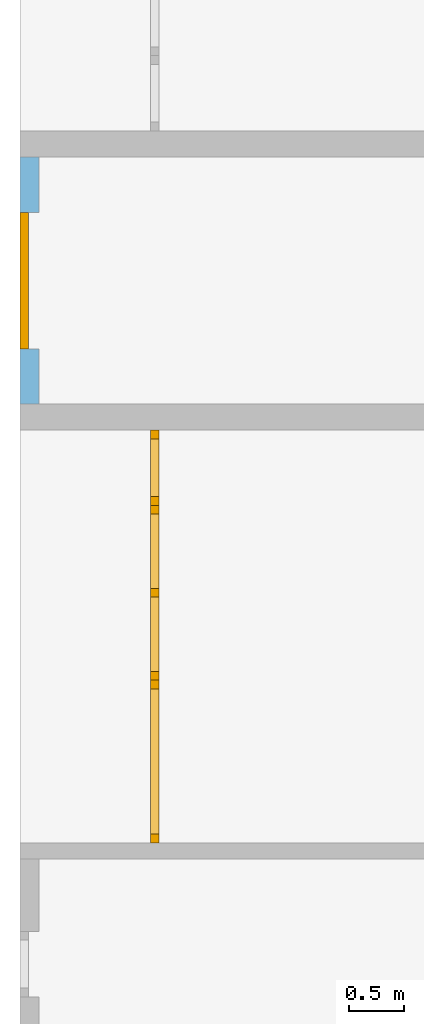
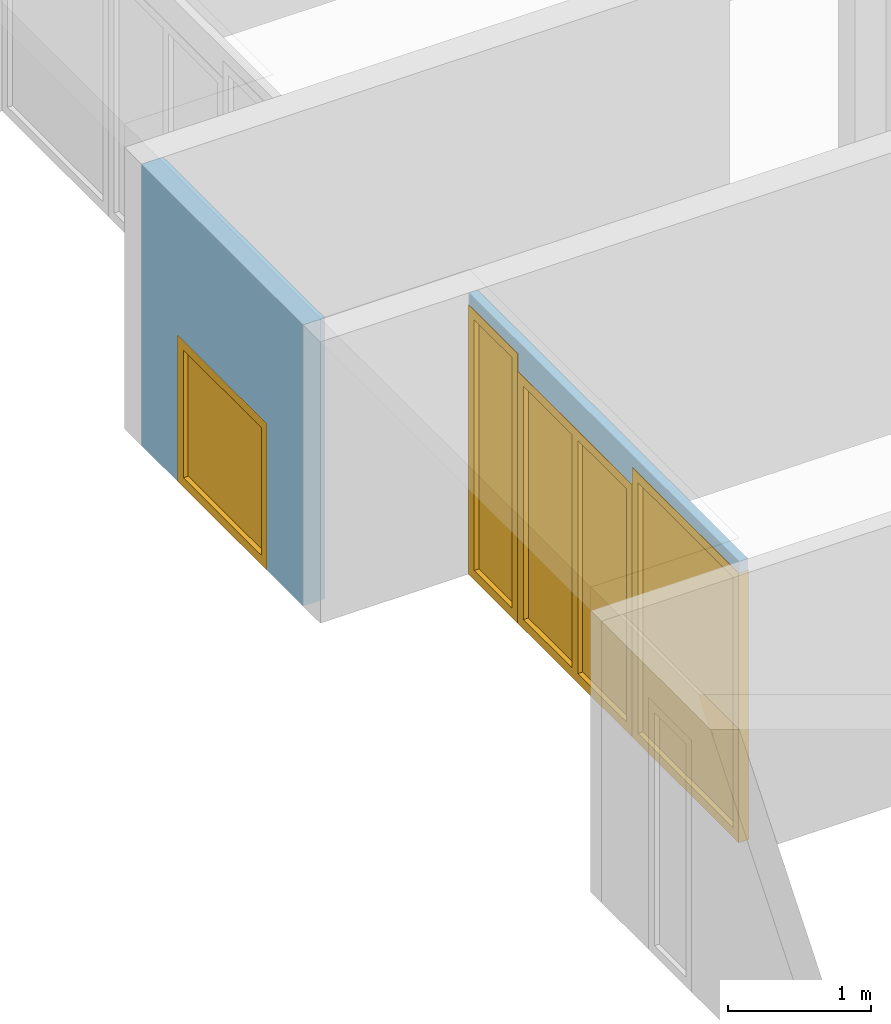
# One storey, part 4 of 8: 2 doors, 2 windows, 4 openings, plus 2 elements that do not belong to this part.
"""IFC2X3 building model written with IfcOpenShell, lengths in millimetres."""

from ifc_helpers import new_model, entity, si_unit, converted_unit, frame, frame_2d, origin, origin_with_axes, place, context, project, spatial, rectangle, extrude, faceted_brep, material, layer, layer_set, layer_usage, type_object, element, fill, save


model = new_model("IFC2X3")

# Units and contexts
model_context = context("Model", 3, precision=1e-05, world=origin())
plan_context = context("Plan", 3, precision=1e-05, world=origin())
ifc_project = project(units=[si_unit("LENGTHUNIT", "METRE", prefix="MILLI"), converted_unit("PLANEANGLEUNIT", "DEGREE", entity("IfcPlaneAngleMeasure", 0.0174532925199433), si_unit("PLANEANGLEUNIT", "RADIAN"), dimensions=[0, 0, 0, 0, 0, 0, 0]), si_unit("AREAUNIT", "SQUARE_METRE"), si_unit("VOLUMEUNIT", "CUBIC_METRE")], contexts=[model_context, plan_context])

# Building, storey
building_placement = place(None, origin())
building = spatial("IfcBuilding", under=ifc_project, at=building_placement, CompositionType="ELEMENT")
storey_placement = place(building_placement, frame((0.0, 0.0, 2900.0), z_axis=(0.0, 0.0, 1.0), x_axis=(1.0, 0.0, 0.0)))
storey = spatial("IfcBuildingStorey", under=building, at=storey_placement, Name="OG", CompositionType="ELEMENT", Elevation=2900.0)

# Wall, opening, window
ifc_material_1 = material(Name="B25")
ifc_layer_1 = layer(ifc_material_1, 175.0)
ifc_layer_set_1 = layer_set([ifc_layer_1])
ifc_layer_usage_1 = layer_usage(ifc_layer_set_1, "AXIS2", "POSITIVE", 0.0)
wall_1_placement = place(storey_placement, frame((21188.3517822139, 1688.4375, 0.0), z_axis=(0.0, 0.0, 1.0), x_axis=(-1.64835853914244e-12, -1.0, 0.0)))
wall_1 = element("IfcWallStandardCase", 1, at=wall_1_placement, inside=storey, material=ifc_layer_usage_1, context=model_context, shape_type="SweptSolid", body=[
    extrude(rectangle(XDim=2260.0, YDim=175.0, at=frame_2d((1130.0, 87.5), x_axis=(1.0, 0.0))), origin_with_axes(), (0.0, 0.0, 1.0), 2400.0),
])
opening_1_placement = place(wall_1_placement, frame((505.000000000001, -8.54925019665361e-13, 0.0), z_axis=(0.0, 1.0, 0.0), x_axis=(0.0, 0.0, 1.0)))
opening_1 = element("IfcOpeningElement", 2, at=opening_1_placement, cuts=wall_1, ObjectType="Opening", context=model_context, shape_type="SweptSolid", body=[
    extrude(rectangle(XDim=1250.0, YDim=1250.0, at=frame_2d((625.0, 625.0), x_axis=(1.0, 0.0))), origin_with_axes(), (0.0, 0.0, 1.0), 175.0),
])
ifc_material_2 = material()
window_1_placement = place(opening_1_placement, frame((0.0, 0.0, 0.0), z_axis=(1.0, 0.0, 0.0), x_axis=(0.0, 1.0, 0.0)))
window_1 = element("IfcWindow", 3, at=window_1_placement, inside=storey, material=ifc_material_2, Name="m", OverallHeight=1250.0, OverallWidth=1250.0, context=model_context, shape_type="Brep", body=[
    faceted_brep([(79.9999999997119, -8.9765050947932e-10, 0.0), (-2.88082446786575e-10, -1.02951436264931e-09, 0.0), (-2.88082446786575e-10, -1.02951436264931e-09, 1250.0), (79.9999999997119, -8.9765050947932e-10, 1250.0), (-4.1995917854365e-10, 79.9999999989705, 0.0), (79.99999999958, 79.9999999991024, 0.0), (79.99999999958, 79.9999999991024, 1250.0), (-4.1995917854365e-10, 79.9999999989705, 1250.0), (-2.88082446786575e-10, -1.02951436264931e-09, 0.0), (79.9999999997119, -8.9765050947932e-10, 0.0), (79.99999999958, 79.9999999991024, 0.0), (-4.1995917854365e-10, 79.9999999989705, 0.0), (-2.88082446786575e-10, -1.02951436264931e-09, 1250.0), (-2.88082446786575e-10, -1.02951436264931e-09, 0.0), (-4.1995917854365e-10, 79.9999999989705, 0.0), (-4.1995917854365e-10, 79.9999999989705, 1250.0), (79.9999999997119, -8.9765050947932e-10, 1250.0), (-2.88082446786575e-10, -1.02951436264931e-09, 1250.0), (-4.1995917854365e-10, 79.9999999989705, 1250.0), (79.99999999958, 79.9999999991024, 1250.0), (79.9999999997119, -8.9765050947932e-10, 0.0), (79.9999999997119, -8.9765050947932e-10, 1250.0), (79.99999999958, 79.9999999991024, 1250.0), (79.99999999958, 79.9999999991024, 0.0)], [[[0, 1, 2, 3]], [[4, 5, 6, 7]], [[8, 9, 10, 11]], [[12, 13, 14, 15]], [[16, 17, 18, 19]], [[20, 21, 22, 23]]], orient=[[False], [False], [False], [False], [False], [False]]),
    faceted_brep([(1170.00000000013, 8.98979335417494e-10, 1250.0), (1250.00000000013, 1.03084307756518e-09, 1250.0), (1250.00000000013, 1.03084307756518e-09, 0.0), (1170.00000000013, 8.98979335417494e-10, 0.0), (1250.0, 80.0000000010309, 1250.0), (1170.0, 80.000000000899, 1250.0), (1170.0, 80.000000000899, 0.0), (1250.0, 80.0000000010309, 0.0), (1250.00000000013, 1.03084307756518e-09, 1250.0), (1170.00000000013, 8.98979335417494e-10, 1250.0), (1170.0, 80.000000000899, 1250.0), (1250.0, 80.0000000010309, 1250.0), (1250.00000000013, 1.03084307756518e-09, 0.0), (1250.00000000013, 1.03084307756518e-09, 1250.0), (1250.0, 80.0000000010309, 1250.0), (1250.0, 80.0000000010309, 0.0), (1170.00000000013, 8.98979335417494e-10, 0.0), (1250.00000000013, 1.03084307756518e-09, 0.0), (1250.0, 80.0000000010309, 0.0), (1170.0, 80.000000000899, 0.0), (1170.00000000013, 8.98979335417494e-10, 1250.0), (1170.00000000013, 8.98979335417494e-10, 0.0), (1170.0, 80.000000000899, 0.0), (1170.0, 80.000000000899, 1250.0)], [[[0, 1, 2, 3]], [[4, 5, 6, 7]], [[8, 9, 10, 11]], [[12, 13, 14, 15]], [[16, 17, 18, 19]], [[20, 21, 22, 23]]], orient=[[False], [False], [False], [False], [False], [False]]),
    faceted_brep([(1170.00000000013, 8.98965124562778e-10, 80.0), (1170.00000000013, 8.98965124562778e-10, 0.0), (79.9999999997137, -8.9767893118875e-10, 0.0), (79.9999999997137, -8.9767893118875e-10, 80.0), (1170.0, 80.000000000899, 0.0), (1170.0, 80.000000000899, 80.0), (79.9999999995819, 79.9999999991023, 80.0), (79.9999999995819, 79.9999999991023, 0.0), (1170.00000000013, 8.98965124562778e-10, 0.0), (1170.00000000013, 8.98965124562778e-10, 80.0), (1170.0, 80.000000000899, 80.0), (1170.0, 80.000000000899, 0.0), (79.9999999997137, -8.9767893118875e-10, 0.0), (1170.00000000013, 8.98965124562778e-10, 0.0), (1170.0, 80.000000000899, 0.0), (79.9999999995819, 79.9999999991023, 0.0), (79.9999999997137, -8.9767893118875e-10, 80.0), (79.9999999997137, -8.9767893118875e-10, 0.0), (79.9999999995819, 79.9999999991023, 0.0), (79.9999999995819, 79.9999999991023, 80.0), (1170.00000000013, 8.98965124562778e-10, 80.0), (79.9999999997137, -8.9767893118875e-10, 80.0), (79.9999999995819, 79.9999999991023, 80.0), (1170.0, 80.000000000899, 80.0)], [[[0, 1, 2, 3]], [[4, 5, 6, 7]], [[8, 9, 10, 11]], [[12, 13, 14, 15]], [[16, 17, 18, 19]], [[20, 21, 22, 23]]], orient=[[False], [False], [False], [False], [False], [False]]),
    faceted_brep([(79.9999999997137, -8.9767893118875e-10, 1170.0), (79.9999999997137, -8.9767893118875e-10, 1250.0), (1170.00000000013, 8.98965124562778e-10, 1250.0), (1170.00000000013, 8.98965124562778e-10, 1170.0), (79.9999999995819, 79.9999999991023, 1250.0), (79.9999999995819, 79.9999999991023, 1170.0), (1170.0, 80.000000000899, 1170.0), (1170.0, 80.000000000899, 1250.0), (79.9999999997137, -8.9767893118875e-10, 1250.0), (79.9999999997137, -8.9767893118875e-10, 1170.0), (79.9999999995819, 79.9999999991023, 1170.0), (79.9999999995819, 79.9999999991023, 1250.0), (1170.00000000013, 8.98965124562778e-10, 1250.0), (79.9999999997137, -8.9767893118875e-10, 1250.0), (79.9999999995819, 79.9999999991023, 1250.0), (1170.0, 80.000000000899, 1250.0), (1170.00000000013, 8.98965124562778e-10, 1170.0), (1170.00000000013, 8.98965124562778e-10, 1250.0), (1170.0, 80.000000000899, 1250.0), (1170.0, 80.000000000899, 1170.0), (79.9999999997137, -8.9767893118875e-10, 1170.0), (1170.00000000013, 8.98965124562778e-10, 1170.0), (1170.0, 80.000000000899, 1170.0), (79.9999999995819, 79.9999999991023, 1170.0)], [[[0, 1, 2, 3]], [[4, 5, 6, 7]], [[8, 9, 10, 11]], [[12, 13, 14, 15]], [[16, 17, 18, 19]], [[20, 21, 22, 23]]], orient=[[False], [False], [False], [False], [False], [False]]),
    faceted_brep([(1170.00000000007, 40.000000000899, 1170.0), (1170.00000000007, 40.000000000899, 80.0), (79.9999999996455, 39.9999999991023, 80.0), (79.9999999996455, 39.9999999991023, 1170.0), (1170.00000000006, 41.000000000899, 1170.0), (79.9999999996439, 40.9999999991023, 1170.0), (79.9999999996439, 40.9999999991023, 80.0), (1170.00000000006, 41.000000000899, 80.0), (1170.00000000007, 40.000000000899, 1170.0), (1170.00000000006, 41.000000000899, 1170.0), (1170.00000000006, 41.000000000899, 80.0), (1170.00000000007, 40.000000000899, 80.0), (1170.00000000007, 40.000000000899, 80.0), (1170.00000000006, 41.000000000899, 80.0), (79.9999999996439, 40.9999999991023, 80.0), (79.9999999996455, 39.9999999991023, 80.0), (79.9999999996455, 39.9999999991023, 80.0), (79.9999999996439, 40.9999999991023, 80.0), (79.9999999996439, 40.9999999991023, 1170.0), (79.9999999996455, 39.9999999991023, 1170.0), (79.9999999996455, 39.9999999991023, 1170.0), (79.9999999996439, 40.9999999991023, 1170.0), (1170.00000000006, 41.000000000899, 1170.0), (1170.00000000007, 40.000000000899, 1170.0)], [[[0, 1, 2, 3]], [[4, 5, 6, 7]], [[8, 9, 10, 11]], [[12, 13, 14, 15]], [[16, 17, 18, 19]], [[20, 21, 22, 23]]], orient=[[False], [False], [False], [False], [False], [False]]),
])
fill(opening_1, window_1)

# Wall, openings, doors, window
ifc_material_3 = material(Name="glas")
ifc_layer_2 = layer(ifc_material_3, 70.0)
ifc_layer_set_2 = layer_set([ifc_layer_2])
ifc_layer_usage_2 = layer_usage(ifc_layer_set_2, "AXIS2", "POSITIVE", 0.0)
wall_2_placement = place(storey_placement, frame((22458.3517822139, -4591.5625, 0.0), z_axis=(0.0, 0.0, 1.0), x_axis=(0.0, 1.0, 0.0)))
wall_2 = element("IfcWallStandardCase", 4, at=wall_2_placement, inside=storey, material=ifc_layer_usage_2, context=model_context, shape_type="SweptSolid", body=[
    extrude(rectangle(XDim=3780.0, YDim=70.0, at=frame_2d((1890.0, 35.0), x_axis=(1.0, 0.0))), origin_with_axes(), (0.0, 0.0, 1.0), 2400.0),
])
opening_2_placement = place(wall_2_placement, frame((1490.0, 0.0, 0.0), z_axis=(0.0, 1.0, 0.0), x_axis=(0.0, 0.0, 1.0)))
opening_2 = element("IfcOpeningElement", 5, at=opening_2_placement, cuts=wall_2, ObjectType="Opening", context=model_context, shape_type="SweptSolid", body=[
    extrude(rectangle(XDim=2150.0, YDim=1600.0, at=frame_2d((1075.0, 800.0), x_axis=(1.0, 0.0))), origin_with_axes(), (0.0, 0.0, 1.0), 70.0),
])
opening_3_placement = place(wall_2_placement, frame((3090.0, 0.0, 0.0), z_axis=(0.0, 1.0, 0.0), x_axis=(0.0, 0.0, 1.0)))
opening_3 = element("IfcOpeningElement", 6, at=opening_3_placement, cuts=wall_2, ObjectType="Opening", context=model_context, shape_type="SweptSolid", body=[
    extrude(rectangle(XDim=2300.0, YDim=689.999999999996, at=frame_2d((1150.0, 344.999999999998), x_axis=(1.0, 0.0))), origin_with_axes(), (0.0, 0.0, 1.0), 70.0),
])
opening_4_placement = place(wall_2_placement, frame((0.0, 0.0, 0.0), z_axis=(0.0, 1.0, 0.0), x_axis=(0.0, 0.0, 1.0)))
opening_4 = element("IfcOpeningElement", 7, at=opening_4_placement, cuts=wall_2, ObjectType="Opening", context=model_context, shape_type="SweptSolid", body=[
    extrude(rectangle(XDim=2300.0, YDim=1490.0, at=frame_2d((1150.0, 745.0), x_axis=(1.0, 0.0))), origin_with_axes(), (0.0, 0.0, 1.0), 70.0),
])
ifc_material_4 = material()
door_style_1 = type_object("IfcDoorStyle", Name="Verglasung 01", ConstructionType="NOTDEFINED", OperationType="USERDEFINED", ParameterTakesPrecedence=False, Sizeable=False)
door_1_placement = place(opening_3_placement, frame((0.0, 0.0, 0.0), z_axis=(1.0, 0.0, 0.0), x_axis=(0.0, 1.0, 0.0)))
door_1 = element("IfcDoor", 8, at=door_1_placement, inside=storey, type_object=door_style_1, material=ifc_material_4, Name="Verglasung 01", OverallHeight=2300.0, OverallWidth=690.0, context=model_context, shape_type="Brep", body=[
    faceted_brep([(609.999999999996, 75.0000000000014, 0.0), (689.999999999996, 75.0000000000014, 0.0), (689.999999999996, 75.0000000000014, 2300.0), (609.999999999996, 75.0000000000014, 2300.0), (689.999999999996, -4.99999999999859, 0.0), (609.999999999996, -4.99999999999859, 0.0), (609.999999999996, -4.99999999999859, 2300.0), (689.999999999996, -4.99999999999859, 2300.0), (689.999999999996, 75.0000000000014, 0.0), (609.999999999996, 75.0000000000014, 0.0), (609.999999999996, -4.99999999999859, 0.0), (689.999999999996, -4.99999999999859, 0.0), (689.999999999996, 75.0000000000014, 2300.0), (689.999999999996, 75.0000000000014, 0.0), (689.999999999996, -4.99999999999859, 0.0), (689.999999999996, -4.99999999999859, 2300.0), (609.999999999996, 75.0000000000014, 2300.0), (689.999999999996, 75.0000000000014, 2300.0), (689.999999999996, -4.99999999999859, 2300.0), (609.999999999996, -4.99999999999859, 2300.0), (609.999999999996, 75.0000000000014, 0.0), (609.999999999996, 75.0000000000014, 2300.0), (609.999999999996, -4.99999999999859, 2300.0), (609.999999999996, -4.99999999999859, 0.0)], [[[0, 1, 2, 3]], [[4, 5, 6, 7]], [[8, 9, 10, 11]], [[12, 13, 14, 15]], [[16, 17, 18, 19]], [[20, 21, 22, 23]]], orient=[[False], [False], [False], [False], [False], [False]]),
    faceted_brep([(80.0, 75.0000000000015, 2300.0), (3.34279265644953e-16, 75.0000000000015, 2300.0), (3.34279265644953e-16, 75.0000000000015, 0.0), (80.0, 75.0000000000015, 0.0), (-4.56414614964456e-15, -4.99999999999854, 2300.0), (80.0, -4.99999999999854, 2300.0), (80.0, -4.99999999999854, 0.0), (-4.56414614964456e-15, -4.99999999999854, 0.0), (3.34279265644953e-16, 75.0000000000015, 2300.0), (80.0, 75.0000000000015, 2300.0), (80.0, -4.99999999999854, 2300.0), (-4.56414614964456e-15, -4.99999999999854, 2300.0), (3.34279265644953e-16, 75.0000000000015, 0.0), (3.34279265644953e-16, 75.0000000000015, 2300.0), (-4.56414614964456e-15, -4.99999999999854, 2300.0), (-4.56414614964456e-15, -4.99999999999854, 0.0), (80.0, 75.0000000000015, 0.0), (3.34279265644953e-16, 75.0000000000015, 0.0), (-4.56414614964456e-15, -4.99999999999854, 0.0), (80.0, -4.99999999999854, 0.0), (80.0, 75.0000000000015, 2300.0), (80.0, 75.0000000000015, 0.0), (80.0, -4.99999999999854, 0.0), (80.0, -4.99999999999854, 2300.0)], [[[0, 1, 2, 3]], [[4, 5, 6, 7]], [[8, 9, 10, 11]], [[12, 13, 14, 15]], [[16, 17, 18, 19]], [[20, 21, 22, 23]]], orient=[[False], [False], [False], [False], [False], [False]]),
    faceted_brep([(609.999999999996, 75.0000000000014, 2220.0), (609.999999999996, 75.0000000000014, 2300.0), (80.0, 75.0000000000015, 2300.0), (80.0, 75.0000000000015, 2220.0), (609.999999999996, -4.99999999999858, 2300.0), (609.999999999996, -4.99999999999858, 2220.0), (80.0, -4.99999999999854, 2220.0), (80.0, -4.99999999999854, 2300.0), (609.999999999996, 75.0000000000014, 2300.0), (609.999999999996, 75.0000000000014, 2220.0), (609.999999999996, -4.99999999999858, 2220.0), (609.999999999996, -4.99999999999858, 2300.0), (80.0, 75.0000000000015, 2300.0), (609.999999999996, 75.0000000000014, 2300.0), (609.999999999996, -4.99999999999858, 2300.0), (80.0, -4.99999999999854, 2300.0), (80.0, 75.0000000000015, 2220.0), (80.0, 75.0000000000015, 2300.0), (80.0, -4.99999999999854, 2300.0), (80.0, -4.99999999999854, 2220.0), (609.999999999996, 75.0000000000014, 2220.0), (80.0, 75.0000000000015, 2220.0), (80.0, -4.99999999999854, 2220.0), (609.999999999996, -4.99999999999858, 2220.0)], [[[0, 1, 2, 3]], [[4, 5, 6, 7]], [[8, 9, 10, 11]], [[12, 13, 14, 15]], [[16, 17, 18, 19]], [[20, 21, 22, 23]]], orient=[[False], [False], [False], [False], [False], [False]]),
    faceted_brep([(80.0, 75.0000000000015, 80.0), (80.0, 75.0000000000015, 0.0), (609.999999999996, 75.0000000000014, 0.0), (609.999999999996, 75.0000000000014, 80.0), (80.0, -4.99999999999854, 0.0), (80.0, -4.99999999999854, 80.0), (609.999999999996, -4.99999999999858, 80.0), (609.999999999996, -4.99999999999858, 0.0), (80.0, 75.0000000000015, 0.0), (80.0, 75.0000000000015, 80.0), (80.0, -4.99999999999854, 80.0), (80.0, -4.99999999999854, 0.0), (609.999999999996, 75.0000000000014, 0.0), (80.0, 75.0000000000015, 0.0), (80.0, -4.99999999999854, 0.0), (609.999999999996, -4.99999999999858, 0.0), (609.999999999996, 75.0000000000014, 80.0), (609.999999999996, 75.0000000000014, 0.0), (609.999999999996, -4.99999999999858, 0.0), (609.999999999996, -4.99999999999858, 80.0), (80.0, 75.0000000000015, 80.0), (609.999999999996, 75.0000000000014, 80.0), (609.999999999996, -4.99999999999858, 80.0), (80.0, -4.99999999999854, 80.0)], [[[0, 1, 2, 3]], [[4, 5, 6, 7]], [[8, 9, 10, 11]], [[12, 13, 14, 15]], [[16, 17, 18, 19]], [[20, 21, 22, 23]]], orient=[[False], [False], [False], [False], [False], [False]]),
    faceted_brep([(609.999999999996, 35.0000000000014, 80.0), (609.999999999996, 35.0000000000014, 2220.0), (80.0, 35.0000000000015, 2220.0), (80.0, 35.0000000000015, 80.0), (609.999999999996, 34.0000000000014, 80.0), (80.0, 34.0000000000015, 80.0), (80.0, 34.0000000000015, 2220.0), (609.999999999996, 34.0000000000014, 2220.0), (609.999999999996, 35.0000000000014, 80.0), (609.999999999996, 34.0000000000014, 80.0), (609.999999999996, 34.0000000000014, 2220.0), (609.999999999996, 35.0000000000014, 2220.0), (609.999999999996, 35.0000000000014, 2220.0), (609.999999999996, 34.0000000000014, 2220.0), (80.0, 34.0000000000015, 2220.0), (80.0, 35.0000000000015, 2220.0), (80.0, 35.0000000000015, 2220.0), (80.0, 34.0000000000015, 2220.0), (80.0, 34.0000000000015, 80.0), (80.0, 35.0000000000015, 80.0), (80.0, 35.0000000000015, 80.0), (80.0, 34.0000000000015, 80.0), (609.999999999996, 34.0000000000014, 80.0), (609.999999999996, 35.0000000000014, 80.0)], [[[0, 1, 2, 3]], [[4, 5, 6, 7]], [[8, 9, 10, 11]], [[12, 13, 14, 15]], [[16, 17, 18, 19]], [[20, 21, 22, 23]]], orient=[[False], [False], [False], [False], [False], [False]]),
])
fill(opening_3, door_1)
ifc_material_5 = material()
door_style_2 = type_object("IfcDoorStyle", Name="m", ConstructionType="NOTDEFINED", OperationType="USERDEFINED", ParameterTakesPrecedence=False, Sizeable=False)
door_2_placement = place(opening_4_placement, frame((0.0, 0.0, 0.0), z_axis=(1.0, 0.0, 0.0), x_axis=(0.0, 1.0, 0.0)))
door_2 = element("IfcDoor", 9, at=door_2_placement, inside=storey, type_object=door_style_2, material=ifc_material_5, Name="m", OverallHeight=2300.0, OverallWidth=1490.0, context=model_context, shape_type="Brep", body=[
    faceted_brep([(1410.0, 75.0000000000014, 0.0), (1490.0, 75.0000000000014, 0.0), (1490.0, 75.0000000000014, 2300.0), (1410.0, 75.0000000000014, 2300.0), (1490.0, -4.99999999999864, 0.0), (1410.0, -4.99999999999864, 0.0), (1410.0, -4.99999999999864, 2300.0), (1490.0, -4.99999999999864, 2300.0), (1490.0, 75.0000000000014, 0.0), (1410.0, 75.0000000000014, 0.0), (1410.0, -4.99999999999864, 0.0), (1490.0, -4.99999999999864, 0.0), (1490.0, 75.0000000000014, 2300.0), (1490.0, 75.0000000000014, 0.0), (1490.0, -4.99999999999864, 0.0), (1490.0, -4.99999999999864, 2300.0), (1410.0, 75.0000000000014, 2300.0), (1490.0, 75.0000000000014, 2300.0), (1490.0, -4.99999999999864, 2300.0), (1410.0, -4.99999999999864, 2300.0), (1410.0, 75.0000000000014, 0.0), (1410.0, 75.0000000000014, 2300.0), (1410.0, -4.99999999999864, 2300.0), (1410.0, -4.99999999999864, 0.0)], [[[0, 1, 2, 3]], [[4, 5, 6, 7]], [[8, 9, 10, 11]], [[12, 13, 14, 15]], [[16, 17, 18, 19]], [[20, 21, 22, 23]]], orient=[[False], [False], [False], [False], [False], [False]]),
    faceted_brep([(80.0, 75.0000000000015, 2300.0), (3.34279265644953e-16, 75.0000000000015, 2300.0), (3.34279265644953e-16, 75.0000000000015, 0.0), (80.0, 75.0000000000015, 0.0), (-4.56414614964456e-15, -4.99999999999854, 2300.0), (80.0, -4.99999999999854, 2300.0), (80.0, -4.99999999999854, 0.0), (-4.56414614964456e-15, -4.99999999999854, 0.0), (3.34279265644953e-16, 75.0000000000015, 2300.0), (80.0, 75.0000000000015, 2300.0), (80.0, -4.99999999999854, 2300.0), (-4.56414614964456e-15, -4.99999999999854, 2300.0), (3.34279265644953e-16, 75.0000000000015, 0.0), (3.34279265644953e-16, 75.0000000000015, 2300.0), (-4.56414614964456e-15, -4.99999999999854, 2300.0), (-4.56414614964456e-15, -4.99999999999854, 0.0), (80.0, 75.0000000000015, 0.0), (3.34279265644953e-16, 75.0000000000015, 0.0), (-4.56414614964456e-15, -4.99999999999854, 0.0), (80.0, -4.99999999999854, 0.0), (80.0, 75.0000000000015, 2300.0), (80.0, 75.0000000000015, 0.0), (80.0, -4.99999999999854, 0.0), (80.0, -4.99999999999854, 2300.0)], [[[0, 1, 2, 3]], [[4, 5, 6, 7]], [[8, 9, 10, 11]], [[12, 13, 14, 15]], [[16, 17, 18, 19]], [[20, 21, 22, 23]]], orient=[[False], [False], [False], [False], [False], [False]]),
    faceted_brep([(1410.0, 75.0000000000014, 2220.0), (1410.0, 75.0000000000014, 2300.0), (80.0, 75.0000000000015, 2300.0), (80.0, 75.0000000000015, 2220.0), (1410.0, -4.99999999999862, 2300.0), (1410.0, -4.99999999999862, 2220.0), (80.0, -4.99999999999854, 2220.0), (80.0, -4.99999999999854, 2300.0), (1410.0, 75.0000000000014, 2300.0), (1410.0, 75.0000000000014, 2220.0), (1410.0, -4.99999999999862, 2220.0), (1410.0, -4.99999999999862, 2300.0), (80.0, 75.0000000000015, 2300.0), (1410.0, 75.0000000000014, 2300.0), (1410.0, -4.99999999999862, 2300.0), (80.0, -4.99999999999854, 2300.0), (80.0, 75.0000000000015, 2220.0), (80.0, 75.0000000000015, 2300.0), (80.0, -4.99999999999854, 2300.0), (80.0, -4.99999999999854, 2220.0), (1410.0, 75.0000000000014, 2220.0), (80.0, 75.0000000000015, 2220.0), (80.0, -4.99999999999854, 2220.0), (1410.0, -4.99999999999862, 2220.0)], [[[0, 1, 2, 3]], [[4, 5, 6, 7]], [[8, 9, 10, 11]], [[12, 13, 14, 15]], [[16, 17, 18, 19]], [[20, 21, 22, 23]]], orient=[[False], [False], [False], [False], [False], [False]]),
    faceted_brep([(80.0, 75.0000000000015, 80.0), (80.0, 75.0000000000015, 0.0), (1410.0, 75.0000000000014, 0.0), (1410.0, 75.0000000000014, 80.0), (80.0, -4.99999999999854, 0.0), (80.0, -4.99999999999854, 80.0), (1410.0, -4.99999999999862, 80.0), (1410.0, -4.99999999999862, 0.0), (80.0, 75.0000000000015, 0.0), (80.0, 75.0000000000015, 80.0), (80.0, -4.99999999999854, 80.0), (80.0, -4.99999999999854, 0.0), (1410.0, 75.0000000000014, 0.0), (80.0, 75.0000000000015, 0.0), (80.0, -4.99999999999854, 0.0), (1410.0, -4.99999999999862, 0.0), (1410.0, 75.0000000000014, 80.0), (1410.0, 75.0000000000014, 0.0), (1410.0, -4.99999999999862, 0.0), (1410.0, -4.99999999999862, 80.0), (80.0, 75.0000000000015, 80.0), (1410.0, 75.0000000000014, 80.0), (1410.0, -4.99999999999862, 80.0), (80.0, -4.99999999999854, 80.0)], [[[0, 1, 2, 3]], [[4, 5, 6, 7]], [[8, 9, 10, 11]], [[12, 13, 14, 15]], [[16, 17, 18, 19]], [[20, 21, 22, 23]]], orient=[[False], [False], [False], [False], [False], [False]]),
    faceted_brep([(1410.0, 35.0000000000014, 80.0), (1410.0, 35.0000000000014, 2220.0), (80.0, 35.0000000000015, 2220.0), (80.0, 35.0000000000015, 80.0), (1410.0, 34.0000000000014, 80.0), (80.0, 34.0000000000015, 80.0), (80.0, 34.0000000000015, 2220.0), (1410.0, 34.0000000000014, 2220.0), (1410.0, 35.0000000000014, 80.0), (1410.0, 34.0000000000014, 80.0), (1410.0, 34.0000000000014, 2220.0), (1410.0, 35.0000000000014, 2220.0), (1410.0, 35.0000000000014, 2220.0), (1410.0, 34.0000000000014, 2220.0), (80.0, 34.0000000000015, 2220.0), (80.0, 35.0000000000015, 2220.0), (80.0, 35.0000000000015, 2220.0), (80.0, 34.0000000000015, 2220.0), (80.0, 34.0000000000015, 80.0), (80.0, 35.0000000000015, 80.0), (80.0, 35.0000000000015, 80.0), (80.0, 34.0000000000015, 80.0), (1410.0, 34.0000000000014, 80.0), (1410.0, 35.0000000000014, 80.0)], [[[0, 1, 2, 3]], [[4, 5, 6, 7]], [[8, 9, 10, 11]], [[12, 13, 14, 15]], [[16, 17, 18, 19]], [[20, 21, 22, 23]]], orient=[[False], [False], [False], [False], [False], [False]]),
])
fill(opening_4, door_2)
ifc_material_6 = material()
window_2_placement = place(opening_2_placement, frame((0.0, 0.0, 0.0), z_axis=(1.0, 0.0, 0.0), x_axis=(0.0, 1.0, 0.0)))
window_2 = element("IfcWindow", 10, at=window_2_placement, inside=storey, material=ifc_material_6, Name="m", OverallHeight=2150.0, OverallWidth=1600.0, context=model_context, shape_type="Brep", body=[
    faceted_brep([(1520.0, 75.0000000000014, 0.0), (1600.0, 75.0000000000014, 0.0), (1600.0, 75.0000000000014, 2150.0), (1520.0, 75.0000000000014, 2150.0), (1600.0, -4.99999999999865, 0.0), (1520.0, -4.99999999999865, 0.0), (1520.0, -4.99999999999865, 2150.0), (1600.0, -4.99999999999865, 2150.0), (1600.0, 75.0000000000014, 0.0), (1520.0, 75.0000000000014, 0.0), (1520.0, -4.99999999999865, 0.0), (1600.0, -4.99999999999865, 0.0), (1600.0, 75.0000000000014, 2150.0), (1600.0, 75.0000000000014, 0.0), (1600.0, -4.99999999999865, 0.0), (1600.0, -4.99999999999865, 2150.0), (1520.0, 75.0000000000014, 2150.0), (1600.0, 75.0000000000014, 2150.0), (1600.0, -4.99999999999865, 2150.0), (1520.0, -4.99999999999865, 2150.0), (1520.0, 75.0000000000014, 0.0), (1520.0, 75.0000000000014, 2150.0), (1520.0, -4.99999999999865, 2150.0), (1520.0, -4.99999999999865, 0.0)], [[[0, 1, 2, 3]], [[4, 5, 6, 7]], [[8, 9, 10, 11]], [[12, 13, 14, 15]], [[16, 17, 18, 19]], [[20, 21, 22, 23]]], orient=[[False], [False], [False], [False], [False], [False]]),
    faceted_brep([(80.0, 75.0000000000015, 2150.0), (3.34279265644953e-16, 75.0000000000015, 2150.0), (3.34279265644953e-16, 75.0000000000015, 0.0), (80.0, 75.0000000000015, 0.0), (-4.56414614964456e-15, -4.99999999999854, 2150.0), (80.0, -4.99999999999854, 2150.0), (80.0, -4.99999999999854, 0.0), (-4.56414614964456e-15, -4.99999999999854, 0.0), (3.34279265644953e-16, 75.0000000000015, 2150.0), (80.0, 75.0000000000015, 2150.0), (80.0, -4.99999999999854, 2150.0), (-4.56414614964456e-15, -4.99999999999854, 2150.0), (3.34279265644953e-16, 75.0000000000015, 0.0), (3.34279265644953e-16, 75.0000000000015, 2150.0), (-4.56414614964456e-15, -4.99999999999854, 2150.0), (-4.56414614964456e-15, -4.99999999999854, 0.0), (80.0, 75.0000000000015, 0.0), (3.34279265644953e-16, 75.0000000000015, 0.0), (-4.56414614964456e-15, -4.99999999999854, 0.0), (80.0, -4.99999999999854, 0.0), (80.0, 75.0000000000015, 2150.0), (80.0, 75.0000000000015, 0.0), (80.0, -4.99999999999854, 0.0), (80.0, -4.99999999999854, 2150.0)], [[[0, 1, 2, 3]], [[4, 5, 6, 7]], [[8, 9, 10, 11]], [[12, 13, 14, 15]], [[16, 17, 18, 19]], [[20, 21, 22, 23]]], orient=[[False], [False], [False], [False], [False], [False]]),
    faceted_brep([(80.0, 75.0000000000015, 80.0), (80.0, 75.0000000000015, 0.0), (1520.0, 75.0000000000014, 0.0), (1520.0, 75.0000000000014, 80.0), (80.0, -4.99999999999854, 0.0), (80.0, -4.99999999999854, 80.0), (1520.0, -4.99999999999864, 80.0), (1520.0, -4.99999999999864, 0.0), (80.0, 75.0000000000015, 0.0), (80.0, 75.0000000000015, 80.0), (80.0, -4.99999999999854, 80.0), (80.0, -4.99999999999854, 0.0), (1520.0, 75.0000000000014, 0.0), (80.0, 75.0000000000015, 0.0), (80.0, -4.99999999999854, 0.0), (1520.0, -4.99999999999864, 0.0), (1520.0, 75.0000000000014, 80.0), (1520.0, 75.0000000000014, 0.0), (1520.0, -4.99999999999864, 0.0), (1520.0, -4.99999999999864, 80.0), (80.0, 75.0000000000015, 80.0), (1520.0, 75.0000000000014, 80.0), (1520.0, -4.99999999999864, 80.0), (80.0, -4.99999999999854, 80.0)], [[[0, 1, 2, 3]], [[4, 5, 6, 7]], [[8, 9, 10, 11]], [[12, 13, 14, 15]], [[16, 17, 18, 19]], [[20, 21, 22, 23]]], orient=[[False], [False], [False], [False], [False], [False]]),
    faceted_brep([(1520.0, 75.0000000000014, 2070.0), (1520.0, 75.0000000000014, 2150.0), (80.0, 75.0000000000015, 2150.0), (80.0, 75.0000000000015, 2070.0), (1520.0, -4.99999999999864, 2150.0), (1520.0, -4.99999999999864, 2070.0), (80.0, -4.99999999999854, 2070.0), (80.0, -4.99999999999854, 2150.0), (1520.0, 75.0000000000014, 2150.0), (1520.0, 75.0000000000014, 2070.0), (1520.0, -4.99999999999864, 2070.0), (1520.0, -4.99999999999864, 2150.0), (80.0, 75.0000000000015, 2150.0), (1520.0, 75.0000000000014, 2150.0), (1520.0, -4.99999999999864, 2150.0), (80.0, -4.99999999999854, 2150.0), (80.0, 75.0000000000015, 2070.0), (80.0, 75.0000000000015, 2150.0), (80.0, -4.99999999999854, 2150.0), (80.0, -4.99999999999854, 2070.0), (1520.0, 75.0000000000014, 2070.0), (80.0, 75.0000000000015, 2070.0), (80.0, -4.99999999999854, 2070.0), (1520.0, -4.99999999999864, 2070.0)], [[[0, 1, 2, 3]], [[4, 5, 6, 7]], [[8, 9, 10, 11]], [[12, 13, 14, 15]], [[16, 17, 18, 19]], [[20, 21, 22, 23]]], orient=[[False], [False], [False], [False], [False], [False]]),
    faceted_brep([(760.0, 75.0000000000014, 80.0), (840.0, 75.0000000000014, 80.0), (840.0, 75.0000000000014, 2070.0), (760.0, 75.0000000000014, 2070.0), (840.0, -4.99999999999861, 80.0), (760.0, -4.99999999999859, 80.0), (760.0, -4.99999999999859, 2070.0), (840.0, -4.99999999999861, 2070.0), (840.0, 75.0000000000014, 80.0), (760.0, 75.0000000000014, 80.0), (760.0, -4.99999999999859, 80.0), (840.0, -4.99999999999861, 80.0), (840.0, 75.0000000000014, 2070.0), (840.0, 75.0000000000014, 80.0), (840.0, -4.99999999999861, 80.0), (840.0, -4.99999999999861, 2070.0), (760.0, 75.0000000000014, 2070.0), (840.0, 75.0000000000014, 2070.0), (840.0, -4.99999999999861, 2070.0), (760.0, -4.99999999999859, 2070.0), (760.0, 75.0000000000014, 80.0), (760.0, 75.0000000000014, 2070.0), (760.0, -4.99999999999859, 2070.0), (760.0, -4.99999999999859, 80.0)], [[[0, 1, 2, 3]], [[4, 5, 6, 7]], [[8, 9, 10, 11]], [[12, 13, 14, 15]], [[16, 17, 18, 19]], [[20, 21, 22, 23]]], orient=[[False], [False], [False], [False], [False], [False]]),
    faceted_brep([(80.0, 35.0000000000015, 2070.0), (80.0, 35.0000000000015, 80.0), (760.0, 35.0000000000014, 80.0), (760.0, 35.0000000000014, 2070.0), (80.0, 34.0000000000015, 2070.0), (760.0, 34.0000000000014, 2070.0), (760.0, 34.0000000000014, 80.0), (80.0, 34.0000000000015, 80.0), (80.0, 35.0000000000015, 2070.0), (80.0, 34.0000000000015, 2070.0), (80.0, 34.0000000000015, 80.0), (80.0, 35.0000000000015, 80.0), (80.0, 35.0000000000015, 80.0), (80.0, 34.0000000000015, 80.0), (760.0, 34.0000000000014, 80.0), (760.0, 35.0000000000014, 80.0), (760.0, 35.0000000000014, 80.0), (760.0, 34.0000000000014, 80.0), (760.0, 34.0000000000014, 2070.0), (760.0, 35.0000000000014, 2070.0), (760.0, 35.0000000000014, 2070.0), (760.0, 34.0000000000014, 2070.0), (80.0, 34.0000000000015, 2070.0), (80.0, 35.0000000000015, 2070.0)], [[[0, 1, 2, 3]], [[4, 5, 6, 7]], [[8, 9, 10, 11]], [[12, 13, 14, 15]], [[16, 17, 18, 19]], [[20, 21, 22, 23]]], orient=[[False], [False], [False], [False], [False], [False]]),
    faceted_brep([(840.0, 35.0000000000014, 2070.0), (840.0, 35.0000000000014, 80.0), (1520.0, 35.0000000000014, 80.0), (1520.0, 35.0000000000014, 2070.0), (840.0, 34.0000000000014, 2070.0), (1520.0, 34.0000000000014, 2070.0), (1520.0, 34.0000000000014, 80.0), (840.0, 34.0000000000014, 80.0), (840.0, 35.0000000000014, 2070.0), (840.0, 34.0000000000014, 2070.0), (840.0, 34.0000000000014, 80.0), (840.0, 35.0000000000014, 80.0), (840.0, 35.0000000000014, 80.0), (840.0, 34.0000000000014, 80.0), (1520.0, 34.0000000000014, 80.0), (1520.0, 35.0000000000014, 80.0), (1520.0, 35.0000000000014, 80.0), (1520.0, 34.0000000000014, 80.0), (1520.0, 34.0000000000014, 2070.0), (1520.0, 35.0000000000014, 2070.0), (1520.0, 35.0000000000014, 2070.0), (1520.0, 34.0000000000014, 2070.0), (840.0, 34.0000000000014, 2070.0), (840.0, 35.0000000000014, 2070.0)], [[[0, 1, 2, 3]], [[4, 5, 6, 7]], [[8, 9, 10, 11]], [[12, 13, 14, 15]], [[16, 17, 18, 19]], [[20, 21, 22, 23]]], orient=[[False], [False], [False], [False], [False], [False]]),
])
fill(opening_2, window_2)

save(model, "model.ifc")
